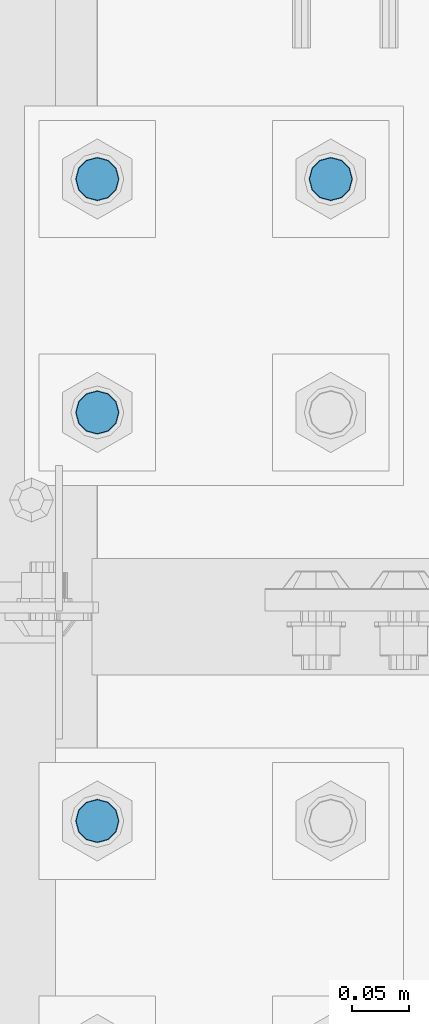
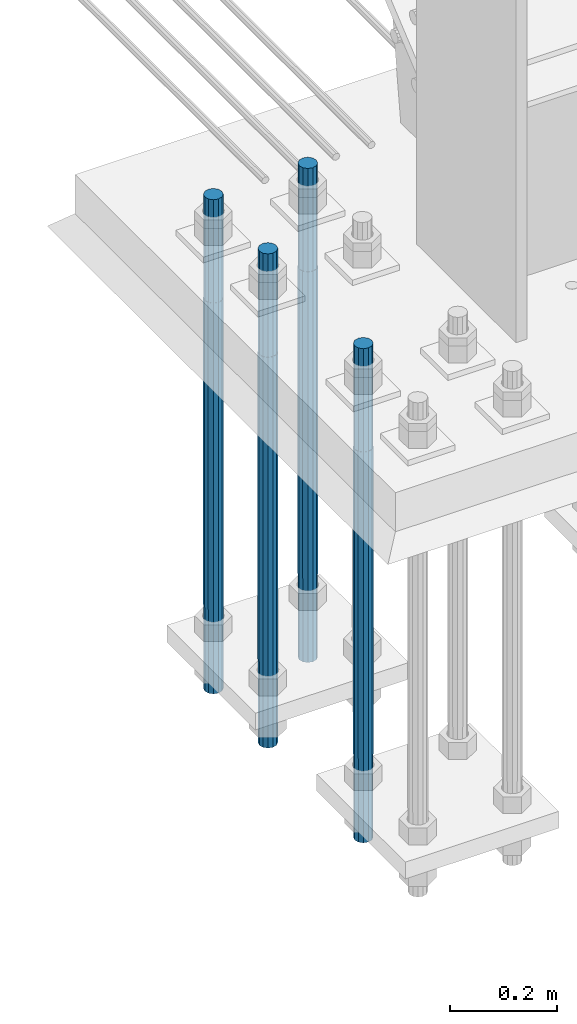
# One storey, part 1289 of 3843: 4 columns, 1 element without a shape of its own.
"""IFC2X3 building model written with IfcOpenShell, lengths in millimetres."""

import ifcopenshell
import ifcopenshell.guid

model = None  # the IFC model being written
_history = None  # IfcOwnerHistory: only IFC2X3 demands one
_inside = {}  # id of a spatial element -> (the spatial element, [elements in it])
_under = {}  # id of a project, library or spatial element -> (it, [spatial elements below it])
_declared = {}  # id of a project -> (the project, [libraries it declares])
_typed = {}  # id of a type object -> (the type object, [elements of that type])
_made_of = {}  # id of a material, layer set ... -> (it, [elements and type objects made of it])


def new_model(schema):
    """Start an empty IFC model of exactly this schema.

    Asked for "IFC4X3", IfcOpenShell would pick the latest addendum, in which some entities
    have other attributes; the version numbers below select the first issue.
    IFC2X3 requires an IfcOwnerHistory on every rooted entity: one is made here for all.
    """
    global model, _history
    if schema == "IFC4X3":
        model = ifcopenshell.file(schema_version=(4, 3, 0, 0))
    else:
        model = ifcopenshell.file(schema=schema)
    _inside.clear()
    _under.clear()
    _declared.clear()
    _typed.clear()
    _made_of.clear()
    _history = None
    if model.schema == "IFC2X3":
        org = make("IfcOrganization", Name="unknown")
        user = make(
            "IfcPersonAndOrganization",
            ThePerson=make("IfcPerson", FamilyName="unknown"),
            TheOrganization=org,
        )
        app = make(
            "IfcApplication",
            ApplicationDeveloper=org,
            Version="unknown",
            ApplicationFullName="unknown",
            ApplicationIdentifier="unknown",
        )
        _history = make(
            "IfcOwnerHistory",
            OwningUser=user,
            OwningApplication=app,
            ChangeAction="ADDED",
            CreationDate=0,
        )
    return model


def make(cls, **values):
    """One entity of the class cls with the attributes given. An attribute that is None is left unset."""
    return model.create_entity(
        cls, **{name: value for name, value in values.items() if value is not None}
    )


def rooted(cls, **values):
    """An entity with a GlobalId (a new one), such as an element, a storey or a relation."""
    return make(cls, GlobalId=ifcopenshell.guid.new(), OwnerHistory=_history, **values)


def si_unit(unit_type, name, prefix=None):
    """IfcSIUnit, for example si_unit("LENGTHUNIT", "METRE", prefix="MILLI")."""
    return make("IfcSIUnit", UnitType=unit_type, Prefix=prefix, Name=name)


def assignment(units):
    """IfcUnitAssignment: the units of a project."""
    return None if units is None else make("IfcUnitAssignment", Units=units)


def point(xyz):
    """IfcCartesianPoint."""
    return None if xyz is None else make("IfcCartesianPoint", Coordinates=xyz)


def direction(xyz):
    """IfcDirection."""
    return None if xyz is None else make("IfcDirection", DirectionRatios=xyz)


def frame(location, z_axis=None, x_axis=None):
    """IfcAxis2Placement3D, a coordinate frame: its origin and axes. An axis left out is left unset."""
    return make(
        "IfcAxis2Placement3D",
        Location=point(location),
        Axis=direction(z_axis),
        RefDirection=direction(x_axis),
    )


def origin_with_axes():
    """The frame at (0, 0, 0) with the z axis (0, 0, 1) and the x axis (1, 0, 0) written out."""
    return frame((0.0, 0.0, 0.0), z_axis=(0.0, 0.0, 1.0), x_axis=(1.0, 0.0, 0.0))


def place(relative_to, where):
    """IfcLocalPlacement: puts the frame where relative to a parent placement (None: the world)."""
    return make(
        "IfcLocalPlacement", PlacementRelTo=relative_to, RelativePlacement=where
    )


def context(
    kind, dimensions, precision=None, world=None, true_north=None, identifier=None
):
    """IfcGeometricRepresentationContext, for example the 3D "Model" context."""
    return make(
        "IfcGeometricRepresentationContext",
        ContextIdentifier=identifier,
        ContextType=kind,
        CoordinateSpaceDimension=dimensions,
        Precision=precision,
        WorldCoordinateSystem=world,
        TrueNorth=true_north,
    )


def subcontext(parent, identifier, kind, view, scale=None):
    """IfcGeometricRepresentationSubContext, for example "Body" below "Model"."""
    return make(
        "IfcGeometricRepresentationSubContext",
        ContextIdentifier=identifier,
        ContextType=kind,
        ParentContext=parent,
        TargetScale=scale,
        TargetView=view,
    )


def project(units=None, contexts=None):
    """IfcProject with its units and contexts."""
    return rooted(
        "IfcProject",
        Name="project",
        RepresentationContexts=contexts,
        UnitsInContext=assignment(units),
    )


def spatial(cls, under=None, at=None, **own):
    """A site, building, storey or space (cls), placed at a placement, below another one or the project."""
    s = rooted(cls, ObjectPlacement=at, **own)
    if under is not None:
        _under.setdefault(under.id(), (under, []))[1].append(s)
    return s


def faces_of(points, faces, orient=None, outer=None):
    """IfcFace entities. A face is a list of loops; a loop is a list of indices into points, from 0.

    orient and outer hold one flag for each loop. By default every Orientation is true, the
    first loop of a face is its IfcFaceOuterBound and the others are IfcFaceBound.
    """
    made = []
    for i, loops in enumerate(faces):
        bounds = []
        for j, loop in enumerate(loops):
            is_outer = j == 0 if outer is None else outer[i][j]
            bounds.append(
                make(
                    "IfcFaceOuterBound" if is_outer else "IfcFaceBound",
                    Bound=make("IfcPolyLoop", Polygon=[points[k] for k in loop]),
                    Orientation=True if orient is None else orient[i][j],
                )
            )
        made.append(make("IfcFace", Bounds=bounds))
    return made


def faceted_brep(points, faces, orient=None, outer=None, voids=None):
    """IfcFacetedBrep: a solid bounded by flat faces; with voids (closed shells), ...WithVoids."""
    shared = [point(p) for p in points]
    hull = make("IfcClosedShell", CfsFaces=faces_of(shared, faces, orient, outer))
    if voids is None:
        return make("IfcFacetedBrep", Outer=hull)
    return make(
        "IfcFacetedBrepWithVoids",
        Outer=hull,
        Voids=[
            make(cls, CfsFaces=faces_of(shared, fs, o, b)) for cls, fs, o, b in voids
        ],
    )


def shape(context_of_items, identifier, shape_type, items):
    """IfcShapeRepresentation: the items that make up one representation, for example the "Body"."""
    return make(
        "IfcShapeRepresentation",
        ContextOfItems=context_of_items,
        RepresentationIdentifier=identifier,
        RepresentationType=shape_type,
        Items=items,
    )


def material(Name=None, Category=None):
    """IfcMaterial."""
    return make("IfcMaterial", Name=Name, Category=Category)


def made_of(thing, what):
    """Note that an element or type object is made of a material, layer set ...; save() writes the relation."""
    if what is not None:
        _made_of.setdefault(what.id(), (what, []))[1].append(thing)
    return thing


def type_object(cls, material=None, **own):
    """A type object (cls), such as IfcWallType, which elements share."""
    return made_of(rooted(cls, **own), material)


def element(
    cls,
    number,
    at=None,
    inside=None,
    cuts=None,
    type_object=None,
    material=None,
    context=None,
    identifier="Body",
    shape_type=None,
    held_by="IfcProductDefinitionShape",
    body=None,
    shapes=None,
    **own,
):
    """One element of the class cls, such as IfcWall. Its Tag is "e" and its number.

    at: its placement. inside: the storey or other place that contains it. cuts: it is an
    opening in that element (IfcRelVoidsElement). A single representation is given by context,
    identifier, shape_type and body (its items); several are given by shapes. held_by: the class
    of the entity that holds the representations. save() writes the other relations.
    """
    e = rooted(cls, Tag="e%d" % number, ObjectPlacement=at, **own)
    if body is not None:
        shapes = [shape(context, identifier, shape_type, body)]
    if shapes is not None:
        e.Representation = make(held_by, Representations=shapes)
    if inside is not None:
        _inside.setdefault(inside.id(), (inside, []))[1].append(e)
    if cuts is not None:
        rooted(
            "IfcRelVoidsElement", RelatingBuildingElement=cuts, RelatedOpeningElement=e
        )
    if type_object is not None:
        _typed.setdefault(type_object.id(), (type_object, []))[1].append(e)
    return made_of(e, material)


def aggregate(whole, parts):
    """IfcRelAggregates: a whole, such as a stair, and the parts it consists of."""
    return rooted("IfcRelAggregates", RelatingObject=whole, RelatedObjects=parts)


def save(model, path):
    """Write the relations noted so far, then the file.

    IfcRelAggregates (storeys below a building ...), IfcRelContainedInSpatialStructure (elements
    in a storey), IfcRelDefinesByType, IfcRelAssociatesMaterial and IfcRelDeclares: one each for
    every whole, place, type object, material and project.
    """
    for whole, parts in _under.values():
        aggregate(whole, parts)
    for where, things in _inside.values():
        rooted(
            "IfcRelContainedInSpatialStructure",
            RelatedElements=things,
            RelatingStructure=where,
        )
    for kind, things in _typed.values():
        rooted("IfcRelDefinesByType", RelatedObjects=things, RelatingType=kind)
    for what, things in _made_of.values():
        rooted("IfcRelAssociatesMaterial", RelatedObjects=things, RelatingMaterial=what)
    for by, libraries in _declared.values():
        rooted("IfcRelDeclares", RelatingContext=by, RelatedDefinitions=libraries)
    model.write(path)


model = new_model("IFC2X3")

# Units and contexts
model_context = context("Model", 3, precision=1e-05, world=origin_with_axes())
body_context = subcontext(model_context, "Body", "Model", "MODEL_VIEW")
ifc_project = project(units=[si_unit("LENGTHUNIT", "METRE", prefix="MILLI"), si_unit("AREAUNIT", "SQUARE_METRE"), si_unit("VOLUMEUNIT", "CUBIC_METRE"), si_unit("MASSUNIT", "GRAM", prefix="KILO"), si_unit("TIMEUNIT", "SECOND"), si_unit("PLANEANGLEUNIT", "RADIAN"), si_unit("SOLIDANGLEUNIT", "STERADIAN"), si_unit("THERMODYNAMICTEMPERATUREUNIT", "DEGREE_CELSIUS"), si_unit("LUMINOUSINTENSITYUNIT", "LUMEN")], contexts=[model_context])

# Site, building, storey
site_placement = place(None, origin_with_axes())
site = spatial("IfcSite", under=ifc_project, at=site_placement, CompositionType="ELEMENT")
building_placement = place(site_placement, origin_with_axes())
building = spatial("IfcBuilding", under=site, at=building_placement, Name="Undefined", CompositionType="ELEMENT")
storey_placement = place(building_placement, origin_with_axes())
storey = spatial("IfcBuildingStorey", under=building, at=storey_placement, Name="Undefined", CompositionType="ELEMENT", Elevation=0.0)

# Assembly, columns
assembly_placement = place(storey_placement, origin_with_axes())
assembly = element("IfcElementAssembly", 1, at=assembly_placement, inside=storey, Name="TEMPLATE", AssemblyPlace="NOTDEFINED", PredefinedType="RIGID_FRAME")
ifc_material = material(Name="Undefined/F1554-GR.55")
column_type = type_object("IfcColumnType", PredefinedType="NOTDEFINED")
column_1_placement = place(assembly_placement, frame((76708.0, 15379.7, 30022.8), z_axis=(-1.0, 0.0, 0.0), x_axis=(0.0, 0.0, -1.0)))
column_1 = element("IfcColumn", 2, at=column_1_placement, type_object=column_type, material=ifc_material, Name="ANCHOR_ROD", context=body_context, shape_type="Brep", body=[
    faceted_brep([(-234.950000000001, -16.0214699700155, 9.25), (-234.950000000001, -9.25, 16.0214699700155), (-234.950000000001, 0.0, 18.5), (-234.950000000001, 9.25, 16.0214699700155), (-234.950000000001, 16.0214699700155, 9.25), (-234.950000000001, 18.5, 0.0), (-234.950000000001, 16.0214699700155, -9.25), (-234.950000000001, 9.25, -16.0214699700155), (-234.950000000001, 0.0, -18.5), (-234.950000000001, -9.25, -16.0214699700155), (-234.950000000001, -16.0214699700155, -9.25), (-234.950000000001, -18.5, 0.0), (0.0, 18.5, 0.0), (0.0, 16.0214699700118, -9.25), (0.0, 9.25, -16.0214699700155), (0.0, 0.0, -18.5), (0.0, -9.25, -16.0214699700155), (0.0, -16.0214699700118, -9.25), (0.0, -18.5, 0.0), (0.0, -16.0214699700118, 9.25), (0.0, -9.25, 16.0214699700155), (0.0, 0.0, 18.5), (0.0, 9.25, 16.0214699700155), (0.0, 16.0214699700118, 9.25), (0.0, -16.4977839420972, 9.52500000000146), (0.0, -9.52500000000146, 16.4977839420972), (0.0, 0.0, 19.0499989999989), (0.0, 9.52500000000146, 16.4977839420972), (0.0, 16.4977839420972, 9.52500000000146), (0.0, 19.0500000000029, 0.0), (0.0, 16.4977839420972, -9.52500000000146), (0.0, 9.52500000000146, -16.4977839420972), (0.0, 0.0, -19.0499989999989), (0.0, -9.52500000000146, -16.4977839420972), (0.0, -16.4977839420972, -9.52500000000146), (0.0, -19.0500000000029, 0.0), (698.5, -19.0499999999993, 0.0), (698.5, -16.4977839420935, 9.52499999999418), (698.5, -9.52500000000146, 16.4977839420899), (698.5, 0.0, 19.0500000000029), (698.5, 9.52500000000146, 16.4977839420899), (698.5, 16.4977839420935, 9.52499999999418), (698.5, 19.0499999999993, 0.0), (698.5, 16.4977839420935, -9.52499999999418), (698.5, 9.52500000000146, -16.4977839420899), (698.5, 0.0, -19.0500000000029), (698.5, -9.52500000000146, -16.4977839420899), (698.5, -16.4977839420935, -9.52499999999418), (698.5, -9.25, 16.0214699700155), (698.5, 0.0, 18.5), (698.5, 9.25, 16.0214699700155), (698.5, 16.0214699700118, 9.25), (698.5, 18.5, 0.0), (698.5, 16.0214699700118, -9.25), (698.5, 9.25, -16.0214699700155), (698.5, 0.0, -18.5), (698.5, -9.25, -16.0214699700155), (698.5, -16.0214699700118, -9.25), (698.5, -18.5, 0.0), (698.5, -16.0214699700118, 9.25), (889.0, -9.25, -16.0214699700155), (889.0, 0.0, -18.5), (889.0, 9.25, -16.0214699700155), (889.0, 16.0214699700118, -9.25), (889.0, 18.5, 0.0), (889.0, 16.0214699700118, 9.25), (889.0, 9.25, 16.0214699700155), (889.0, 0.0, 18.5), (889.0, -9.25, 16.0214699700155), (889.0, -16.0214699700118, 9.25), (889.0, -18.5, 0.0), (889.0, -16.0214699700118, -9.25)], [[[0, 1, 2, 3, 4, 5, 6, 7, 8, 9, 10, 11]], [[6, 5, 12, 13]], [[7, 6, 13, 14]], [[8, 7, 14, 15]], [[9, 8, 15, 16]], [[10, 9, 16, 17]], [[11, 10, 17, 18]], [[0, 11, 18, 19]], [[1, 0, 19, 20]], [[2, 1, 20, 21]], [[3, 2, 21, 22]], [[4, 3, 22, 23]], [[5, 4, 23, 12]], [[24, 25, 26, 27, 28, 29, 30, 31, 32, 33, 34, 35], [22, 21, 20, 19, 18, 17, 16, 15, 14, 13, 12, 23]], [[24, 35, 36, 37]], [[25, 24, 37, 38]], [[26, 25, 38, 39]], [[27, 26, 39, 40]], [[28, 27, 40, 41]], [[29, 28, 41, 42]], [[30, 29, 42, 43]], [[31, 30, 43, 44]], [[32, 31, 44, 45]], [[33, 32, 45, 46]], [[34, 33, 46, 47]], [[35, 34, 47, 36]], [[46, 45, 44, 43, 42, 41, 40, 39, 38, 37, 36, 47], [48, 49, 50, 51, 52, 53, 54, 55, 56, 57, 58, 59]], [[60, 61, 62, 63, 64, 65, 66, 67, 68, 69, 70, 71]], [[68, 67, 49, 48]], [[69, 68, 48, 59]], [[70, 69, 59, 58]], [[71, 70, 58, 57]], [[60, 71, 57, 56]], [[61, 60, 56, 55]], [[62, 61, 55, 54]], [[63, 62, 54, 53]], [[64, 63, 53, 52]], [[65, 64, 52, 51]], [[66, 65, 51, 50]], [[67, 66, 50, 49]]]),
])
column_2_placement = place(assembly_placement, frame((76504.8, 14820.9, 30022.8), z_axis=(1.0, 0.0, 0.0), x_axis=(0.0, 0.0, -1.0)))
column_2 = element("IfcColumn", 3, at=column_2_placement, type_object=column_type, material=ifc_material, Name="ANCHOR_ROD", context=body_context, shape_type="Brep", body=[
    faceted_brep([(-234.950000000001, -16.0214699700155, 9.25), (-234.950000000001, -9.25, 16.0214699700155), (-234.950000000001, 0.0, 18.5), (-234.950000000001, 9.25, 16.0214699700155), (-234.950000000001, 16.0214699700155, 9.25), (-234.950000000001, 18.5, 0.0), (-234.950000000001, 16.0214699700155, -9.25), (-234.950000000001, 9.25, -16.0214699700155), (-234.950000000001, 0.0, -18.5), (-234.950000000001, -9.25, -16.0214699700155), (-234.950000000001, -16.0214699700155, -9.25), (-234.950000000001, -18.5, 0.0), (0.0, 18.5, 0.0), (0.0, 16.0214699700118, -9.25), (0.0, 9.25, -16.0214699700155), (0.0, 0.0, -18.5), (0.0, -9.25, -16.0214699700155), (0.0, -16.0214699700118, -9.25), (0.0, -18.5, 0.0), (0.0, -16.0214699700118, 9.25), (0.0, -9.25, 16.0214699700155), (0.0, 0.0, 18.5), (0.0, 9.25, 16.0214699700155), (0.0, 16.0214699700118, 9.25), (0.0, -16.4977839420972, 9.52500000000146), (0.0, -9.52500000000146, 16.4977839420972), (0.0, 0.0, 19.0499989999989), (0.0, 9.52500000000146, 16.4977839420972), (0.0, 16.4977839420972, 9.52500000000146), (0.0, 19.0500000000029, 0.0), (0.0, 16.4977839420972, -9.52500000000146), (0.0, 9.52500000000146, -16.4977839420972), (0.0, 0.0, -19.0499989999989), (0.0, -9.52500000000146, -16.4977839420972), (0.0, -16.4977839420972, -9.52500000000146), (0.0, -19.0500000000029, 0.0), (698.5, -19.0499999999993, 0.0), (698.5, -16.4977839420935, 9.52499999999418), (698.5, -9.52500000000146, 16.4977839420899), (698.5, 0.0, 19.0500000000029), (698.5, 9.52500000000146, 16.4977839420899), (698.5, 16.4977839420935, 9.52499999999418), (698.5, 19.0499999999993, 0.0), (698.5, 16.4977839420935, -9.52499999999418), (698.5, 9.52500000000146, -16.4977839420899), (698.5, 0.0, -19.0500000000029), (698.5, -9.52500000000146, -16.4977839420899), (698.5, -16.4977839420935, -9.52499999999418), (698.5, -9.25, 16.0214699700155), (698.5, 0.0, 18.5), (698.5, 9.25, 16.0214699700155), (698.5, 16.0214699700118, 9.25), (698.5, 18.5, 0.0), (698.5, 16.0214699700118, -9.25), (698.5, 9.25, -16.0214699700155), (698.5, 0.0, -18.5), (698.5, -9.25, -16.0214699700155), (698.5, -16.0214699700118, -9.25), (698.5, -18.5, 0.0), (698.5, -16.0214699700118, 9.25), (889.0, -9.25, -16.0214699700155), (889.0, 0.0, -18.5), (889.0, 9.25, -16.0214699700155), (889.0, 16.0214699700118, -9.25), (889.0, 18.5, 0.0), (889.0, 16.0214699700118, 9.25), (889.0, 9.25, 16.0214699700155), (889.0, 0.0, 18.5), (889.0, -9.25, 16.0214699700155), (889.0, -16.0214699700118, 9.25), (889.0, -18.5, 0.0), (889.0, -16.0214699700118, -9.25)], [[[0, 1, 2, 3, 4, 5, 6, 7, 8, 9, 10, 11]], [[6, 5, 12, 13]], [[7, 6, 13, 14]], [[8, 7, 14, 15]], [[9, 8, 15, 16]], [[10, 9, 16, 17]], [[11, 10, 17, 18]], [[0, 11, 18, 19]], [[1, 0, 19, 20]], [[2, 1, 20, 21]], [[3, 2, 21, 22]], [[4, 3, 22, 23]], [[5, 4, 23, 12]], [[24, 25, 26, 27, 28, 29, 30, 31, 32, 33, 34, 35], [22, 21, 20, 19, 18, 17, 16, 15, 14, 13, 12, 23]], [[24, 35, 36, 37]], [[25, 24, 37, 38]], [[26, 25, 38, 39]], [[27, 26, 39, 40]], [[28, 27, 40, 41]], [[29, 28, 41, 42]], [[30, 29, 42, 43]], [[31, 30, 43, 44]], [[32, 31, 44, 45]], [[33, 32, 45, 46]], [[34, 33, 46, 47]], [[35, 34, 47, 36]], [[46, 45, 44, 43, 42, 41, 40, 39, 38, 37, 36, 47], [48, 49, 50, 51, 52, 53, 54, 55, 56, 57, 58, 59]], [[60, 61, 62, 63, 64, 65, 66, 67, 68, 69, 70, 71]], [[68, 67, 49, 48]], [[69, 68, 48, 59]], [[70, 69, 59, 58]], [[71, 70, 58, 57]], [[60, 71, 57, 56]], [[61, 60, 56, 55]], [[62, 61, 55, 54]], [[63, 62, 54, 53]], [[64, 63, 53, 52]], [[65, 64, 52, 51]], [[66, 65, 51, 50]], [[67, 66, 50, 49]]]),
])
column_3_placement = place(assembly_placement, frame((76504.8, 15176.5, 30022.8), z_axis=(-1.0, 0.0, 0.0), x_axis=(0.0, 0.0, -1.0)))
column_3 = element("IfcColumn", 4, at=column_3_placement, type_object=column_type, material=ifc_material, Name="ANCHOR_ROD", context=body_context, shape_type="Brep", body=[
    faceted_brep([(-234.950000000001, -16.0214699700155, 9.25), (-234.950000000001, -9.25, 16.0214699700155), (-234.950000000001, 0.0, 18.5), (-234.950000000001, 9.25, 16.0214699700155), (-234.950000000001, 16.0214699700155, 9.25), (-234.950000000001, 18.5, 0.0), (-234.950000000001, 16.0214699700155, -9.25), (-234.950000000001, 9.25, -16.0214699700155), (-234.950000000001, 0.0, -18.5), (-234.950000000001, -9.25, -16.0214699700155), (-234.950000000001, -16.0214699700155, -9.25), (-234.950000000001, -18.5, 0.0), (0.0, 18.5, 0.0), (0.0, 16.0214699700118, -9.25), (0.0, 9.25, -16.0214699700155), (0.0, 0.0, -18.5), (0.0, -9.25, -16.0214699700155), (0.0, -16.0214699700118, -9.25), (0.0, -18.5, 0.0), (0.0, -16.0214699700118, 9.25), (0.0, -9.25, 16.0214699700155), (0.0, 0.0, 18.5), (0.0, 9.25, 16.0214699700155), (0.0, 16.0214699700118, 9.25), (0.0, -16.4977839420972, 9.52500000000146), (0.0, -9.52500000000146, 16.4977839420972), (0.0, 0.0, 19.0499989999989), (0.0, 9.52500000000146, 16.4977839420972), (0.0, 16.4977839420972, 9.52500000000146), (0.0, 19.0500000000029, 0.0), (0.0, 16.4977839420972, -9.52500000000146), (0.0, 9.52500000000146, -16.4977839420972), (0.0, 0.0, -19.0499989999989), (0.0, -9.52500000000146, -16.4977839420972), (0.0, -16.4977839420972, -9.52500000000146), (0.0, -19.0500000000029, 0.0), (698.5, -19.0499999999993, 0.0), (698.5, -16.4977839420935, 9.52499999999418), (698.5, -9.52500000000146, 16.4977839420899), (698.5, 0.0, 19.0500000000029), (698.5, 9.52500000000146, 16.4977839420899), (698.5, 16.4977839420935, 9.52499999999418), (698.5, 19.0499999999993, 0.0), (698.5, 16.4977839420935, -9.52499999999418), (698.5, 9.52500000000146, -16.4977839420899), (698.5, 0.0, -19.0500000000029), (698.5, -9.52500000000146, -16.4977839420899), (698.5, -16.4977839420935, -9.52499999999418), (698.5, -9.25, 16.0214699700155), (698.5, 0.0, 18.5), (698.5, 9.25, 16.0214699700155), (698.5, 16.0214699700118, 9.25), (698.5, 18.5, 0.0), (698.5, 16.0214699700118, -9.25), (698.5, 9.25, -16.0214699700155), (698.5, 0.0, -18.5), (698.5, -9.25, -16.0214699700155), (698.5, -16.0214699700118, -9.25), (698.5, -18.5, 0.0), (698.5, -16.0214699700118, 9.25), (889.0, -9.25, -16.0214699700155), (889.0, 0.0, -18.5), (889.0, 9.25, -16.0214699700155), (889.0, 16.0214699700118, -9.25), (889.0, 18.5, 0.0), (889.0, 16.0214699700118, 9.25), (889.0, 9.25, 16.0214699700155), (889.0, 0.0, 18.5), (889.0, -9.25, 16.0214699700155), (889.0, -16.0214699700118, 9.25), (889.0, -18.5, 0.0), (889.0, -16.0214699700118, -9.25)], [[[0, 1, 2, 3, 4, 5, 6, 7, 8, 9, 10, 11]], [[6, 5, 12, 13]], [[7, 6, 13, 14]], [[8, 7, 14, 15]], [[9, 8, 15, 16]], [[10, 9, 16, 17]], [[11, 10, 17, 18]], [[0, 11, 18, 19]], [[1, 0, 19, 20]], [[2, 1, 20, 21]], [[3, 2, 21, 22]], [[4, 3, 22, 23]], [[5, 4, 23, 12]], [[24, 25, 26, 27, 28, 29, 30, 31, 32, 33, 34, 35], [22, 21, 20, 19, 18, 17, 16, 15, 14, 13, 12, 23]], [[24, 35, 36, 37]], [[25, 24, 37, 38]], [[26, 25, 38, 39]], [[27, 26, 39, 40]], [[28, 27, 40, 41]], [[29, 28, 41, 42]], [[30, 29, 42, 43]], [[31, 30, 43, 44]], [[32, 31, 44, 45]], [[33, 32, 45, 46]], [[34, 33, 46, 47]], [[35, 34, 47, 36]], [[46, 45, 44, 43, 42, 41, 40, 39, 38, 37, 36, 47], [48, 49, 50, 51, 52, 53, 54, 55, 56, 57, 58, 59]], [[60, 61, 62, 63, 64, 65, 66, 67, 68, 69, 70, 71]], [[68, 67, 49, 48]], [[69, 68, 48, 59]], [[70, 69, 59, 58]], [[71, 70, 58, 57]], [[60, 71, 57, 56]], [[61, 60, 56, 55]], [[62, 61, 55, 54]], [[63, 62, 54, 53]], [[64, 63, 53, 52]], [[65, 64, 52, 51]], [[66, 65, 51, 50]], [[67, 66, 50, 49]]]),
])
column_4_placement = place(assembly_placement, frame((76504.8, 15379.7, 30022.8), z_axis=(-1.0, 0.0, 0.0), x_axis=(0.0, 0.0, -1.0)))
column_4 = element("IfcColumn", 5, at=column_4_placement, type_object=column_type, material=ifc_material, Name="ANCHOR_ROD", context=body_context, shape_type="Brep", body=[
    faceted_brep([(-234.950000000001, -16.0214699700155, 9.25), (-234.950000000001, -9.25, 16.0214699700155), (-234.950000000001, 0.0, 18.5), (-234.950000000001, 9.25, 16.0214699700155), (-234.950000000001, 16.0214699700155, 9.25), (-234.950000000001, 18.5, 0.0), (-234.950000000001, 16.0214699700155, -9.25), (-234.950000000001, 9.25, -16.0214699700155), (-234.950000000001, 0.0, -18.5), (-234.950000000001, -9.25, -16.0214699700155), (-234.950000000001, -16.0214699700155, -9.25), (-234.950000000001, -18.5, 0.0), (0.0, 18.5, 0.0), (0.0, 16.0214699700118, -9.25), (0.0, 9.25, -16.0214699700155), (0.0, 0.0, -18.5), (0.0, -9.25, -16.0214699700155), (0.0, -16.0214699700118, -9.25), (0.0, -18.5, 0.0), (0.0, -16.0214699700118, 9.25), (0.0, -9.25, 16.0214699700155), (0.0, 0.0, 18.5), (0.0, 9.25, 16.0214699700155), (0.0, 16.0214699700118, 9.25), (0.0, -16.4977839420972, 9.52500000000146), (0.0, -9.52500000000146, 16.4977839420972), (0.0, 0.0, 19.0499989999989), (0.0, 9.52500000000146, 16.4977839420972), (0.0, 16.4977839420972, 9.52500000000146), (0.0, 19.0500000000029, 0.0), (0.0, 16.4977839420972, -9.52500000000146), (0.0, 9.52500000000146, -16.4977839420972), (0.0, 0.0, -19.0499989999989), (0.0, -9.52500000000146, -16.4977839420972), (0.0, -16.4977839420972, -9.52500000000146), (0.0, -19.0500000000029, 0.0), (698.5, -19.0499999999993, 0.0), (698.5, -16.4977839420935, 9.52499999999418), (698.5, -9.52500000000146, 16.4977839420899), (698.5, 0.0, 19.0500000000029), (698.5, 9.52500000000146, 16.4977839420899), (698.5, 16.4977839420935, 9.52499999999418), (698.5, 19.0499999999993, 0.0), (698.5, 16.4977839420935, -9.52499999999418), (698.5, 9.52500000000146, -16.4977839420899), (698.5, 0.0, -19.0500000000029), (698.5, -9.52500000000146, -16.4977839420899), (698.5, -16.4977839420935, -9.52499999999418), (698.5, -9.25, 16.0214699700155), (698.5, 0.0, 18.5), (698.5, 9.25, 16.0214699700155), (698.5, 16.0214699700118, 9.25), (698.5, 18.5, 0.0), (698.5, 16.0214699700118, -9.25), (698.5, 9.25, -16.0214699700155), (698.5, 0.0, -18.5), (698.5, -9.25, -16.0214699700155), (698.5, -16.0214699700118, -9.25), (698.5, -18.5, 0.0), (698.5, -16.0214699700118, 9.25), (889.0, -9.25, -16.0214699700155), (889.0, 0.0, -18.5), (889.0, 9.25, -16.0214699700155), (889.0, 16.0214699700118, -9.25), (889.0, 18.5, 0.0), (889.0, 16.0214699700118, 9.25), (889.0, 9.25, 16.0214699700155), (889.0, 0.0, 18.5), (889.0, -9.25, 16.0214699700155), (889.0, -16.0214699700118, 9.25), (889.0, -18.5, 0.0), (889.0, -16.0214699700118, -9.25)], [[[0, 1, 2, 3, 4, 5, 6, 7, 8, 9, 10, 11]], [[6, 5, 12, 13]], [[7, 6, 13, 14]], [[8, 7, 14, 15]], [[9, 8, 15, 16]], [[10, 9, 16, 17]], [[11, 10, 17, 18]], [[0, 11, 18, 19]], [[1, 0, 19, 20]], [[2, 1, 20, 21]], [[3, 2, 21, 22]], [[4, 3, 22, 23]], [[5, 4, 23, 12]], [[24, 25, 26, 27, 28, 29, 30, 31, 32, 33, 34, 35], [22, 21, 20, 19, 18, 17, 16, 15, 14, 13, 12, 23]], [[24, 35, 36, 37]], [[25, 24, 37, 38]], [[26, 25, 38, 39]], [[27, 26, 39, 40]], [[28, 27, 40, 41]], [[29, 28, 41, 42]], [[30, 29, 42, 43]], [[31, 30, 43, 44]], [[32, 31, 44, 45]], [[33, 32, 45, 46]], [[34, 33, 46, 47]], [[35, 34, 47, 36]], [[46, 45, 44, 43, 42, 41, 40, 39, 38, 37, 36, 47], [48, 49, 50, 51, 52, 53, 54, 55, 56, 57, 58, 59]], [[60, 61, 62, 63, 64, 65, 66, 67, 68, 69, 70, 71]], [[68, 67, 49, 48]], [[69, 68, 48, 59]], [[70, 69, 59, 58]], [[71, 70, 58, 57]], [[60, 71, 57, 56]], [[61, 60, 56, 55]], [[62, 61, 55, 54]], [[63, 62, 54, 53]], [[64, 63, 53, 52]], [[65, 64, 52, 51]], [[66, 65, 51, 50]], [[67, 66, 50, 49]]]),
])
aggregate(assembly, [column_1, column_2, column_3, column_4])

save(model, "model.ifc")
